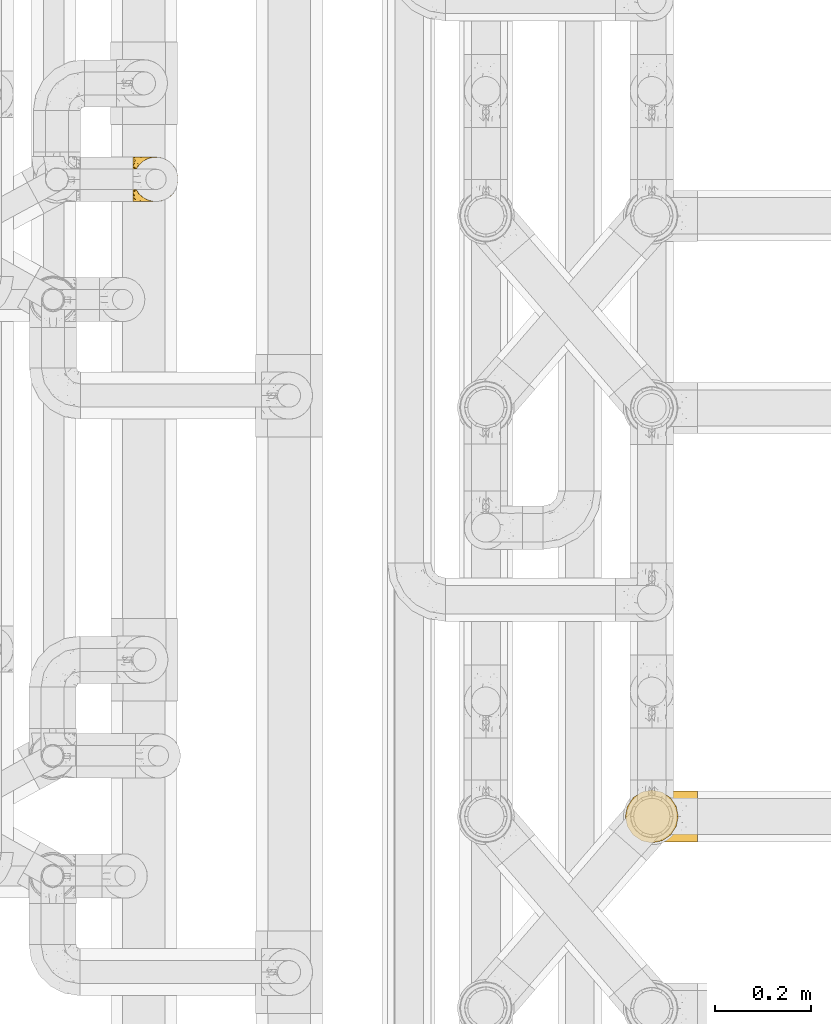
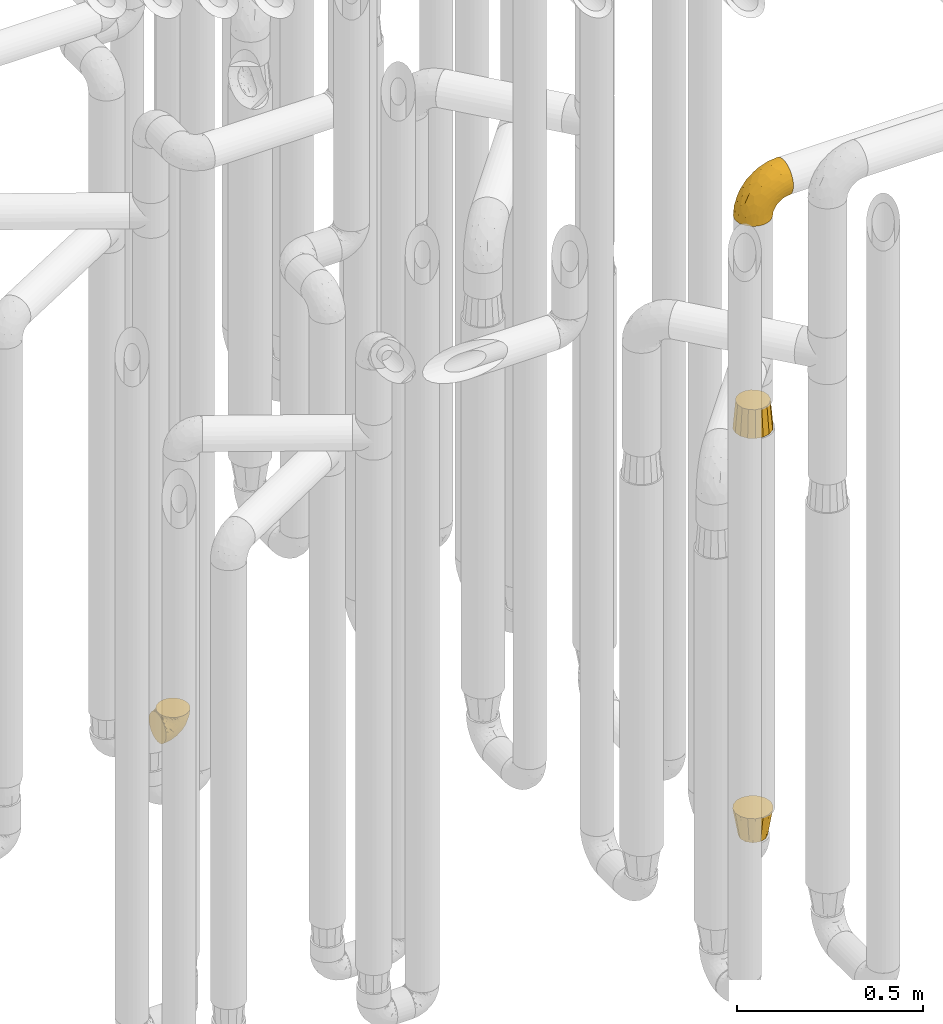
# One storey, part 208 of 827: 4 coverings.
"""IFC2X3 building model written with IfcOpenShell, lengths in millimetres."""

import ifcopenshell
import ifcopenshell.guid

model = None  # the IFC model being written
_history = None  # IfcOwnerHistory: only IFC2X3 demands one
_inside = {}  # id of a spatial element -> (the spatial element, [elements in it])
_under = {}  # id of a project, library or spatial element -> (it, [spatial elements below it])
_declared = {}  # id of a project -> (the project, [libraries it declares])
_typed = {}  # id of a type object -> (the type object, [elements of that type])
_made_of = {}  # id of a material, layer set ... -> (it, [elements and type objects made of it])


def new_model(schema):
    """Start an empty IFC model of exactly this schema.

    Asked for "IFC4X3", IfcOpenShell would pick the latest addendum, in which some entities
    have other attributes; the version numbers below select the first issue.
    IFC2X3 requires an IfcOwnerHistory on every rooted entity: one is made here for all.
    """
    global model, _history
    if schema == "IFC4X3":
        model = ifcopenshell.file(schema_version=(4, 3, 0, 0))
    else:
        model = ifcopenshell.file(schema=schema)
    _inside.clear()
    _under.clear()
    _declared.clear()
    _typed.clear()
    _made_of.clear()
    _history = None
    if model.schema == "IFC2X3":
        org = make("IfcOrganization", Name="unknown")
        user = make(
            "IfcPersonAndOrganization",
            ThePerson=make("IfcPerson", FamilyName="unknown"),
            TheOrganization=org,
        )
        app = make(
            "IfcApplication",
            ApplicationDeveloper=org,
            Version="unknown",
            ApplicationFullName="unknown",
            ApplicationIdentifier="unknown",
        )
        _history = make(
            "IfcOwnerHistory",
            OwningUser=user,
            OwningApplication=app,
            ChangeAction="ADDED",
            CreationDate=0,
        )
    return model


def make(cls, **values):
    """One entity of the class cls with the attributes given. An attribute that is None is left unset."""
    return model.create_entity(
        cls, **{name: value for name, value in values.items() if value is not None}
    )


def entity(cls, *values):
    """Any entity or typed value of the class cls, its attributes in the order of the schema. None: left unset."""
    e = model.create_entity(cls)
    for i, value in enumerate(values):
        if value is not None:
            e[i] = value
    return e


def rooted(cls, **values):
    """An entity with a GlobalId (a new one), such as an element, a storey or a relation."""
    return make(cls, GlobalId=ifcopenshell.guid.new(), OwnerHistory=_history, **values)


def si_unit(unit_type, name, prefix=None):
    """IfcSIUnit, for example si_unit("LENGTHUNIT", "METRE", prefix="MILLI")."""
    return make("IfcSIUnit", UnitType=unit_type, Prefix=prefix, Name=name)


def converted_unit(unit_type, name, factor, base, dimensions=None, offset=None):
    """IfcConversionBasedUnit, such as the inch: factor (a typed value) times the base unit."""
    return make(
        "IfcConversionBasedUnit"
        if offset is None
        else "IfcConversionBasedUnitWithOffset",
        ConversionOffset=offset,
        Dimensions=None
        if dimensions is None
        else entity("IfcDimensionalExponents", *dimensions),
        UnitType=unit_type,
        Name=name,
        ConversionFactor=make(
            "IfcMeasureWithUnit", ValueComponent=factor, UnitComponent=base
        ),
    )


def derived_unit(unit_type, elements):
    """IfcDerivedUnit: a product of units, each with its exponent."""
    return make(
        "IfcDerivedUnit",
        Elements=[
            make("IfcDerivedUnitElement", Unit=unit, Exponent=power)
            for unit, power in elements
        ],
        UnitType=unit_type,
    )


def assignment(units):
    """IfcUnitAssignment: the units of a project."""
    return None if units is None else make("IfcUnitAssignment", Units=units)


def point(xyz):
    """IfcCartesianPoint."""
    return None if xyz is None else make("IfcCartesianPoint", Coordinates=xyz)


def direction(xyz):
    """IfcDirection."""
    return None if xyz is None else make("IfcDirection", DirectionRatios=xyz)


def frame(location, z_axis=None, x_axis=None):
    """IfcAxis2Placement3D, a coordinate frame: its origin and axes. An axis left out is left unset."""
    return make(
        "IfcAxis2Placement3D",
        Location=point(location),
        Axis=direction(z_axis),
        RefDirection=direction(x_axis),
    )


def origin():
    """The frame at (0, 0, 0) with its axes left unset."""
    return frame((0.0, 0.0, 0.0))


def place(relative_to, where):
    """IfcLocalPlacement: puts the frame where relative to a parent placement (None: the world)."""
    return make(
        "IfcLocalPlacement", PlacementRelTo=relative_to, RelativePlacement=where
    )


def context(
    kind, dimensions, precision=None, world=None, true_north=None, identifier=None
):
    """IfcGeometricRepresentationContext, for example the 3D "Model" context."""
    return make(
        "IfcGeometricRepresentationContext",
        ContextIdentifier=identifier,
        ContextType=kind,
        CoordinateSpaceDimension=dimensions,
        Precision=precision,
        WorldCoordinateSystem=world,
        TrueNorth=true_north,
    )


def subcontext(parent, identifier, kind, view, scale=None):
    """IfcGeometricRepresentationSubContext, for example "Body" below "Model"."""
    return make(
        "IfcGeometricRepresentationSubContext",
        ContextIdentifier=identifier,
        ContextType=kind,
        ParentContext=parent,
        TargetScale=scale,
        TargetView=view,
    )


def project(units=None, contexts=None):
    """IfcProject with its units and contexts."""
    return rooted(
        "IfcProject",
        Name="project",
        RepresentationContexts=contexts,
        UnitsInContext=assignment(units),
    )


def spatial(cls, under=None, at=None, **own):
    """A site, building, storey or space (cls), placed at a placement, below another one or the project."""
    s = rooted(cls, ObjectPlacement=at, **own)
    if under is not None:
        _under.setdefault(under.id(), (under, []))[1].append(s)
    return s


def faces_of(points, faces, orient=None, outer=None):
    """IfcFace entities. A face is a list of loops; a loop is a list of indices into points, from 0.

    orient and outer hold one flag for each loop. By default every Orientation is true, the
    first loop of a face is its IfcFaceOuterBound and the others are IfcFaceBound.
    """
    made = []
    for i, loops in enumerate(faces):
        bounds = []
        for j, loop in enumerate(loops):
            is_outer = j == 0 if outer is None else outer[i][j]
            bounds.append(
                make(
                    "IfcFaceOuterBound" if is_outer else "IfcFaceBound",
                    Bound=make("IfcPolyLoop", Polygon=[points[k] for k in loop]),
                    Orientation=True if orient is None else orient[i][j],
                )
            )
        made.append(make("IfcFace", Bounds=bounds))
    return made


def faceted_brep(points, faces, orient=None, outer=None, voids=None):
    """IfcFacetedBrep: a solid bounded by flat faces; with voids (closed shells), ...WithVoids."""
    shared = [point(p) for p in points]
    hull = make("IfcClosedShell", CfsFaces=faces_of(shared, faces, orient, outer))
    if voids is None:
        return make("IfcFacetedBrep", Outer=hull)
    return make(
        "IfcFacetedBrepWithVoids",
        Outer=hull,
        Voids=[
            make(cls, CfsFaces=faces_of(shared, fs, o, b)) for cls, fs, o, b in voids
        ],
    )


def shape(context_of_items, identifier, shape_type, items):
    """IfcShapeRepresentation: the items that make up one representation, for example the "Body"."""
    return make(
        "IfcShapeRepresentation",
        ContextOfItems=context_of_items,
        RepresentationIdentifier=identifier,
        RepresentationType=shape_type,
        Items=items,
    )


def made_of(thing, what):
    """Note that an element or type object is made of a material, layer set ...; save() writes the relation."""
    if what is not None:
        _made_of.setdefault(what.id(), (what, []))[1].append(thing)
    return thing


def element(
    cls,
    number,
    at=None,
    inside=None,
    cuts=None,
    type_object=None,
    material=None,
    context=None,
    identifier="Body",
    shape_type=None,
    held_by="IfcProductDefinitionShape",
    body=None,
    shapes=None,
    **own,
):
    """One element of the class cls, such as IfcWall. Its Tag is "e" and its number.

    at: its placement. inside: the storey or other place that contains it. cuts: it is an
    opening in that element (IfcRelVoidsElement). A single representation is given by context,
    identifier, shape_type and body (its items); several are given by shapes. held_by: the class
    of the entity that holds the representations. save() writes the other relations.
    """
    e = rooted(cls, Tag="e%d" % number, ObjectPlacement=at, **own)
    if body is not None:
        shapes = [shape(context, identifier, shape_type, body)]
    if shapes is not None:
        e.Representation = make(held_by, Representations=shapes)
    if inside is not None:
        _inside.setdefault(inside.id(), (inside, []))[1].append(e)
    if cuts is not None:
        rooted(
            "IfcRelVoidsElement", RelatingBuildingElement=cuts, RelatedOpeningElement=e
        )
    if type_object is not None:
        _typed.setdefault(type_object.id(), (type_object, []))[1].append(e)
    return made_of(e, material)


def aggregate(whole, parts):
    """IfcRelAggregates: a whole, such as a stair, and the parts it consists of."""
    return rooted("IfcRelAggregates", RelatingObject=whole, RelatedObjects=parts)


def save(model, path):
    """Write the relations noted so far, then the file.

    IfcRelAggregates (storeys below a building ...), IfcRelContainedInSpatialStructure (elements
    in a storey), IfcRelDefinesByType, IfcRelAssociatesMaterial and IfcRelDeclares: one each for
    every whole, place, type object, material and project.
    """
    for whole, parts in _under.values():
        aggregate(whole, parts)
    for where, things in _inside.values():
        rooted(
            "IfcRelContainedInSpatialStructure",
            RelatedElements=things,
            RelatingStructure=where,
        )
    for kind, things in _typed.values():
        rooted("IfcRelDefinesByType", RelatedObjects=things, RelatingType=kind)
    for what, things in _made_of.values():
        rooted("IfcRelAssociatesMaterial", RelatedObjects=things, RelatingMaterial=what)
    for by, libraries in _declared.values():
        rooted("IfcRelDeclares", RelatingContext=by, RelatedDefinitions=libraries)
    model.write(path)


model = new_model("IFC2X3")

# Units and contexts
model_context = context("Model", 3, precision=0.01, world=origin(), true_north=direction((6.12303176911189e-17, 1.0)))
body_context = subcontext(model_context, "Body", "Model", "MODEL_VIEW")
ifc_project = project(units=[si_unit("LENGTHUNIT", "METRE", prefix="MILLI"), si_unit("AREAUNIT", "SQUARE_METRE"), si_unit("VOLUMEUNIT", "CUBIC_METRE"), converted_unit("PLANEANGLEUNIT", "DEGREE", entity("IfcRatioMeasure", 0.0174532925199433), si_unit("PLANEANGLEUNIT", "RADIAN"), dimensions=[0, 0, 0, 0, 0, 0, 0]), si_unit("MASSUNIT", "GRAM", prefix="KILO"), derived_unit("MASSDENSITYUNIT", [(si_unit("MASSUNIT", "GRAM", prefix="KILO"), 1), (si_unit("LENGTHUNIT", "METRE"), -3)]), derived_unit("MOMENTOFINERTIAUNIT", [(si_unit("LENGTHUNIT", "METRE"), 4)]), si_unit("TIMEUNIT", "SECOND"), si_unit("FREQUENCYUNIT", "HERTZ"), si_unit("THERMODYNAMICTEMPERATUREUNIT", "DEGREE_CELSIUS"), derived_unit("THERMALTRANSMITTANCEUNIT", [(si_unit("MASSUNIT", "GRAM", prefix="KILO"), 1), (si_unit("THERMODYNAMICTEMPERATUREUNIT", "KELVIN"), -1), (si_unit("TIMEUNIT", "SECOND"), -3)]), derived_unit("VOLUMETRICFLOWRATEUNIT", [(si_unit("LENGTHUNIT", "METRE"), 3), (si_unit("TIMEUNIT", "SECOND"), -1)]), derived_unit("MASSFLOWRATEUNIT", [(si_unit("MASSUNIT", "GRAM", prefix="KILO"), 1), (si_unit("TIMEUNIT", "SECOND"), -1)]), derived_unit("ROTATIONALFREQUENCYUNIT", [(si_unit("TIMEUNIT", "SECOND"), -1)]), si_unit("ELECTRICCURRENTUNIT", "AMPERE"), si_unit("ELECTRICVOLTAGEUNIT", "VOLT"), si_unit("POWERUNIT", "WATT"), si_unit("FORCEUNIT", "NEWTON", prefix="KILO"), si_unit("ILLUMINANCEUNIT", "LUX"), si_unit("LUMINOUSFLUXUNIT", "LUMEN"), si_unit("LUMINOUSINTENSITYUNIT", "CANDELA"), derived_unit("USERDEFINED", [(si_unit("MASSUNIT", "GRAM", prefix="KILO"), -1), (si_unit("LENGTHUNIT", "METRE"), -2), (si_unit("TIMEUNIT", "SECOND"), 3), (si_unit("LUMINOUSFLUXUNIT", "LUMEN"), 1)]), derived_unit("LINEARVELOCITYUNIT", [(si_unit("LENGTHUNIT", "METRE"), 1), (si_unit("TIMEUNIT", "SECOND"), -1)]), si_unit("PRESSUREUNIT", "PASCAL"), derived_unit("USERDEFINED", [(si_unit("LENGTHUNIT", "METRE"), -2), (si_unit("MASSUNIT", "GRAM", prefix="KILO"), 1), (si_unit("TIMEUNIT", "SECOND"), -2)]), derived_unit("LINEARFORCEUNIT", [(si_unit("MASSUNIT", "GRAM", prefix="KILO"), 1), (si_unit("LENGTHUNIT", "METRE"), 1), (si_unit("TIMEUNIT", "SECOND"), -2), (si_unit("LENGTHUNIT", "METRE"), -1)]), derived_unit("PLANARFORCEUNIT", [(si_unit("MASSUNIT", "GRAM", prefix="KILO"), 1), (si_unit("LENGTHUNIT", "METRE"), 1), (si_unit("TIMEUNIT", "SECOND"), -2), (si_unit("LENGTHUNIT", "METRE"), -2)])], contexts=[model_context])

# Site, building, storey
site_placement = place(None, origin())
site = spatial("IfcSite", under=ifc_project, at=site_placement, CompositionType="ELEMENT")
building_placement = place(site_placement, origin())
building = spatial("IfcBuilding", under=site, at=building_placement, CompositionType="ELEMENT")
storey_placement = place(building_placement, frame((0.0, 0.0, 28200.0)))
storey = spatial("IfcBuildingStorey", under=building, at=storey_placement, Name="08", CompositionType="ELEMENT", Elevation=28200.0)

# Coverings
covering_1_placement = place(storey_placement, frame((35893.45, 11758.41, 352.2)))
element("IfcCovering", 1, at=covering_1_placement, inside=storey, Name=":ADSK_", ObjectType=":ADSK_", PredefinedType="INSULATION", context=body_context, shape_type="Brep", body=[
    faceted_brep([(78.41, 11.68, 95.8), (85.72, 19.0, 95.8), (91.22, 27.76, 95.8), (94.64, 37.52, 95.8), (95.8, 47.8, 95.8), (94.64, 58.08, 95.8), (91.22, 67.85, 95.8), (85.71, 76.61, 95.8), (78.39, 83.92, 95.8), (69.63, 89.42, 95.8), (59.87, 92.84, 95.8), (49.6, 94.0, 95.8), (45.45, 93.53, 95.8), (42.38, 93.18, 95.8), (39.31, 92.84, 95.8), (34.43, 91.13, 95.8), (29.54, 89.42, 95.8), (25.16, 86.66, 95.8), (20.78, 83.91, 95.8), (17.13, 80.25, 95.8), (13.47, 76.59, 95.8), (7.97, 67.83, 95.8), (6.26, 62.95, 95.8), (4.55, 58.07, 95.8), (3.4, 47.8, 95.8), (4.55, 37.51, 95.8), (6.26, 32.63, 95.8), (7.97, 27.74, 95.8), (13.48, 18.98, 95.8), (17.14, 15.33, 95.8), (20.8, 11.67, 95.8), (25.18, 8.92, 95.8), (29.56, 6.17, 95.8), (34.44, 4.46, 95.8), (39.32, 2.75, 95.8), (42.39, 2.41, 95.8), (45.45, 2.06, 95.8), (49.6, 1.6, 95.8), (59.88, 2.75, 95.8), (69.65, 6.17, 95.8), (1.6, 47.8, 94.0), (1.6, 59.75, 92.42), (1.6, 70.9, 87.81), (1.6, 75.68, 84.13), (1.6, 80.46, 80.46), (1.6, 84.13, 75.68), (1.6, 87.81, 70.9), (1.6, 90.11, 65.32), (1.6, 92.42, 59.75), (1.6, 92.9, 56.14), (1.6, 93.17, 54.06), (1.6, 93.45, 51.97), (1.6, 94.0, 47.8), (1.6, 92.42, 35.84), (1.6, 87.81, 24.7), (1.6, 80.46, 15.13), (1.6, 70.9, 7.78), (1.6, 59.75, 3.17), (1.6, 47.8, 1.6), (1.6, 35.84, 3.17), (1.6, 24.7, 7.78), (1.6, 15.13, 15.13), (1.6, 7.78, 24.7), (1.6, 3.17, 35.84), (1.6, 1.6, 47.8), (1.6, 2.14, 51.97), (1.6, 2.69, 56.14), (1.6, 3.17, 59.75), (1.6, 5.48, 65.32), (1.6, 7.78, 70.9), (1.6, 11.46, 75.68), (1.6, 15.13, 80.46), (1.6, 19.91, 84.13), (1.6, 24.7, 87.81), (1.6, 35.84, 92.42), (36.81, 23.61, 15.84), (23.28, 31.99, 6.99), (45.8, 35.87, 14.39), (30.7, 47.8, 6.21), (21.2, 40.43, 4.26), (12.96, 47.8, 3.39), (66.19, 31.83, 31.2), (54.51, 23.37, 26.47), (17.98, 21.41, 11.44), (36.69, 3.07, 47.66), (35.54, 1.6, 61.85), (31.64, 1.6, 59.25), (27.75, 1.6, 56.65), (23.86, 1.6, 54.05), (19.96, 1.6, 51.45), (22.8, 13.45, 19.8), (42.67, 15.25, 26.22), (33.21, 8.07, 31.58), (59.45, 16.0, 38.36), (71.5, 17.34, 51.54), (62.66, 10.58, 51.6), (54.5, 5.34, 55.97), (47.57, 2.39, 62.88), (48.81, 8.36, 41.35), (74.98, 10.04, 82.24), (18.7, 2.59, 40.88), (15.75, 6.28, 29.0), (91.17, 34.28, 74.06), (85.28, 38.73, 54.53), (82.58, 27.25, 57.98), (75.78, 29.88, 43.81), (74.98, 38.6, 38.22), (67.27, 23.44, 38.33), (87.38, 25.25, 74.76), (82.04, 17.23, 76.85), (94.0, 47.8, 84.43), (77.8, 47.8, 40.43), (67.38, 47.8, 30.01), (56.2, 2.53, 78.67), (48.85, 1.6, 92.06), (48.11, 1.6, 88.32), (47.57, 1.6, 85.6), (47.03, 1.6, 82.88), (46.48, 1.6, 80.15), (45.94, 1.6, 77.43), (65.78, 5.71, 76.36), (17.24, 1.6, 50.91), (14.51, 1.6, 50.37), (11.79, 1.6, 49.82), (9.07, 1.6, 49.28), (7.2, 1.6, 48.91), (5.33, 1.6, 48.54), (91.18, 47.8, 66.69), (43.34, 1.6, 73.53), (40.74, 1.6, 69.64), (38.14, 1.6, 65.75), (72.73, 11.89, 66.13), (56.96, 47.8, 19.59), (62.23, 39.69, 24.64), (84.49, 47.8, 53.56), (43.83, 47.8, 12.9), (12.05, 13.84, 82.81), (18.95, 9.16, 81.22), (13.02, 15.79, 86.57), (8.34, 25.75, 92.75), (14.63, 16.09, 89.68), (11.09, 7.51, 72.26), (13.66, 3.99, 64.73), (20.08, 2.66, 62.45), (9.61, 3.16, 60.63), (9.48, 2.35, 56.91), (16.1, 2.23, 58.14), (3.42, 38.35, 93.7), (26.63, 6.18, 83.4), (33.72, 2.7, 75.54), (34.77, 2.93, 79.46), (6.75, 16.01, 82.28), (13.31, 9.08, 76.25), (21.11, 9.3, 84.69), (19.94, 11.68, 90.18), (8.67, 4.65, 65.12), (26.11, 3.65, 71.71), (29.3, 3.61, 75.21), (6.32, 12.8, 78.6), (39.92, 2.43, 87.27), (27.05, 6.83, 87.92), (6.04, 21.65, 86.94), (34.4, 3.7, 86.1), (2.87, 47.8, 94.52), (20.92, 3.37, 66.23), (27.43, 7.03, 91.08), (7.54, 7.87, 71.77), (18.45, 7.26, 76.21), (23.88, 3.41, 68.59), (7.77, 23.81, 89.94), (13.3, 86.5, 76.25), (11.09, 88.08, 72.26), (6.33, 82.79, 78.6), (9.07, 94.0, 49.28), (5.33, 94.0, 48.54), (14.51, 94.0, 50.37), (11.79, 94.0, 49.82), (3.42, 57.24, 93.7), (7.76, 71.76, 89.95), (47.03, 94.0, 82.88), (47.57, 94.0, 85.6), (48.85, 94.0, 92.06), (48.11, 94.0, 88.32), (14.62, 79.49, 89.68), (27.03, 88.75, 87.92), (20.08, 92.93, 62.45), (20.92, 92.22, 66.24), (27.75, 94.0, 56.65), (31.64, 94.0, 59.25), (9.61, 92.43, 60.63), (9.48, 93.24, 56.91), (8.33, 69.82, 92.76), (6.74, 79.57, 82.28), (12.04, 81.74, 82.81), (23.86, 94.0, 54.05), (19.96, 94.0, 51.45), (16.1, 93.36, 58.14), (19.93, 83.9, 90.18), (21.1, 86.28, 84.7), (39.92, 93.16, 87.25), (33.68, 92.88, 75.58), (29.28, 91.98, 75.2), (26.62, 89.41, 83.39), (26.08, 91.93, 71.7), (18.93, 86.42, 81.22), (27.87, 88.82, 90.73), (34.75, 92.66, 79.47), (6.04, 73.93, 86.94), (38.14, 94.0, 65.75), (12.79, 79.5, 86.75), (34.41, 91.89, 86.08), (45.94, 94.0, 77.43), (43.34, 94.0, 73.53), (40.74, 94.0, 69.64), (13.66, 91.6, 64.73), (17.24, 94.0, 50.91), (8.67, 90.94, 65.12), (35.54, 94.0, 61.85), (23.83, 92.16, 68.62), (18.43, 88.32, 76.22), (6.03, 86.13, 74.03), (46.48, 94.0, 80.15), (34.52, 93.2, 49.81), (21.2, 55.16, 4.26), (23.82, 82.02, 19.95), (41.32, 84.29, 30.61), (47.62, 76.94, 25.71), (52.66, 68.33, 22.43), (36.81, 71.98, 15.85), (49.75, 92.52, 60.69), (19.07, 92.9, 40.49), (45.8, 59.72, 14.39), (23.28, 63.6, 6.99), (21.35, 88.89, 29.56), (17.98, 74.18, 11.45), (82.57, 68.35, 57.98), (91.17, 61.33, 74.06), (85.27, 56.86, 54.52), (73.89, 68.62, 43.47), (66.19, 63.76, 31.2), (62.43, 72.19, 33.27), (63.53, 88.69, 64.26), (58.45, 92.19, 74.29), (67.16, 89.75, 80.41), (62.22, 55.9, 24.64), (81.54, 77.99, 73.62), (74.8, 85.21, 78.98), (75.83, 74.99, 53.69), (41.45, 90.23, 42.86), (76.72, 59.86, 41.67), (88.2, 70.75, 79.66), (71.6, 81.72, 58.41), (56.23, 86.53, 47.11), (59.44, 79.6, 38.37)], [[[0, 1, 2, 3, 4, 5, 6, 7, 8, 9, 10, 11, 12, 13, 14, 15, 16, 17, 18, 19, 20, 21, 22, 23, 24, 25, 26, 27, 28, 29, 30, 31, 32, 33, 34, 35, 36, 37, 38, 39]], [[40, 41, 42, 43, 44, 45, 46, 47, 48, 49, 50, 51, 52, 53, 54, 55, 56, 57, 58, 59, 60, 61, 62, 63, 64, 65, 66, 67, 68, 69, 70, 71, 72, 73, 74]], [[75, 76, 77]], [[78, 79, 80]], [[77, 81, 82]], [[76, 75, 83]], [[84, 85, 86, 87, 88, 89]], [[90, 91, 92]], [[76, 60, 59]], [[93, 94, 95]], [[90, 62, 61]], [[83, 61, 60]], [[96, 97, 84]], [[98, 93, 95]], [[0, 39, 99]], [[100, 84, 89]], [[62, 101, 63]], [[2, 102, 3]], [[92, 84, 100]], [[103, 102, 104]], [[103, 105, 106]], [[93, 107, 94]], [[1, 108, 2]], [[92, 101, 90]], [[108, 1, 109]], [[102, 110, 3]], [[93, 82, 107]], [[102, 108, 104]], [[111, 106, 112]], [[109, 0, 99]], [[113, 37, 114, 115, 116, 117, 118, 119]], [[120, 38, 113]], [[100, 89, 121, 122, 123, 124, 125, 126, 64]], [[127, 102, 103]], [[97, 119, 128, 129, 130, 85]], [[99, 120, 131]], [[132, 133, 77]], [[59, 80, 79]], [[1, 0, 109]], [[98, 84, 92]], [[94, 109, 131]], [[120, 39, 38]], [[93, 91, 82]], [[104, 94, 105]], [[97, 113, 119]], [[95, 120, 96]], [[83, 90, 61]], [[91, 93, 98]], [[64, 63, 100]], [[100, 63, 101]], [[77, 76, 79]], [[133, 106, 81]], [[84, 97, 85]], [[113, 96, 120]], [[113, 97, 96]], [[37, 113, 38]], [[110, 102, 127]], [[110, 4, 3]], [[103, 111, 134, 127]], [[90, 75, 91]], [[82, 81, 107]], [[91, 75, 82]], [[77, 82, 75]], [[76, 83, 60]], [[90, 83, 75]], [[105, 107, 81]], [[94, 131, 95]], [[105, 94, 107]], [[109, 94, 104]], [[120, 95, 131]], [[98, 95, 96]], [[84, 98, 96]], [[98, 92, 91]], [[106, 105, 81]], [[103, 104, 105]], [[112, 106, 133]], [[103, 106, 111]], [[112, 133, 132]], [[81, 77, 133]], [[77, 78, 135, 132]], [[120, 99, 39]], [[109, 99, 131]], [[59, 58, 80]], [[59, 79, 76]], [[90, 101, 62]], [[100, 101, 92]], [[2, 108, 102]], [[109, 104, 108]], [[78, 77, 79]], [[136, 137, 138]], [[27, 139, 140]], [[141, 142, 143]], [[144, 145, 121]], [[146, 89, 88]], [[147, 139, 25]], [[148, 149, 150]], [[136, 151, 152]], [[147, 40, 74]], [[24, 147, 25]], [[140, 153, 154]], [[33, 116, 34]], [[73, 72, 151]], [[114, 37, 36, 35, 34, 116, 115]], [[146, 155, 144]], [[156, 85, 130]], [[157, 149, 148]], [[151, 158, 152]], [[117, 33, 159]], [[29, 154, 160]], [[161, 74, 73]], [[162, 128, 119]], [[66, 65, 64, 126, 125, 124, 123, 122, 67]], [[163, 147, 24]], [[27, 140, 28]], [[149, 129, 150]], [[139, 27, 26, 25]], [[68, 144, 69]], [[129, 128, 150]], [[164, 87, 86]], [[130, 129, 149]], [[122, 145, 67]], [[154, 153, 148]], [[162, 119, 159]], [[165, 30, 160]], [[150, 160, 148]], [[128, 162, 150]], [[30, 165, 31]], [[145, 144, 68]], [[89, 146, 144]], [[87, 164, 143]], [[166, 155, 142]], [[88, 87, 143]], [[162, 160, 150]], [[160, 30, 29]], [[154, 29, 28]], [[140, 154, 28]], [[160, 154, 148]], [[140, 137, 153]], [[157, 148, 153]], [[156, 130, 157]], [[153, 137, 157]], [[157, 137, 156]], [[167, 137, 136]], [[168, 85, 156]], [[152, 168, 167]], [[167, 168, 156]], [[164, 152, 141]], [[71, 158, 72]], [[152, 167, 136]], [[88, 142, 146]], [[144, 155, 69]], [[146, 142, 155]], [[70, 166, 71]], [[142, 141, 166]], [[70, 69, 155]], [[141, 158, 71]], [[161, 73, 151]], [[138, 137, 140]], [[161, 136, 169]], [[136, 161, 151]], [[74, 161, 169]], [[152, 158, 141]], [[151, 72, 158]], [[168, 152, 164]], [[137, 167, 156]], [[164, 86, 168]], [[85, 168, 86]], [[116, 33, 117]], [[130, 149, 157]], [[67, 145, 68]], [[121, 89, 144]], [[145, 122, 121]], [[40, 147, 163]], [[169, 147, 74]], [[159, 33, 32]], [[162, 159, 32]], [[159, 119, 118, 117]], [[139, 147, 169]], [[139, 169, 138]], [[162, 32, 31]], [[141, 143, 164]], [[88, 143, 142]], [[71, 166, 141]], [[155, 166, 70]], [[139, 138, 140]], [[169, 136, 138]], [[160, 162, 165]], [[162, 31, 165]], [[170, 171, 172]], [[173, 174, 52, 51, 50, 49, 48, 175, 176]], [[177, 178, 41]], [[179, 15, 180]], [[12, 11, 181, 182, 180, 14, 13]], [[183, 21, 20]], [[19, 18, 184]], [[185, 186, 187]], [[186, 188, 187]], [[43, 172, 44]], [[189, 190, 47]], [[23, 22, 21, 191]], [[170, 192, 193]], [[40, 163, 177]], [[194, 195, 196]], [[24, 23, 177]], [[197, 198, 183]], [[199, 15, 179]], [[47, 46, 189]], [[200, 201, 202]], [[201, 203, 204]], [[205, 206, 184]], [[207, 41, 178]], [[16, 15, 199]], [[14, 180, 15]], [[202, 201, 198]], [[208, 201, 200]], [[163, 24, 177]], [[48, 47, 190]], [[196, 195, 189]], [[197, 184, 202]], [[204, 193, 209]], [[210, 211, 212]], [[206, 212, 213]], [[205, 17, 210]], [[184, 206, 202]], [[210, 212, 206]], [[185, 194, 214]], [[189, 215, 190]], [[216, 45, 214]], [[186, 171, 170]], [[189, 216, 196]], [[197, 20, 19]], [[194, 185, 187]], [[197, 183, 20]], [[184, 197, 19]], [[197, 202, 198]], [[206, 200, 202]], [[204, 183, 198]], [[201, 208, 203]], [[203, 208, 217]], [[204, 198, 201]], [[217, 188, 218]], [[193, 219, 170]], [[171, 186, 185]], [[170, 218, 186]], [[170, 219, 218]], [[42, 207, 192]], [[171, 220, 172]], [[216, 189, 46]], [[214, 194, 196]], [[44, 220, 45]], [[214, 196, 216]], [[216, 46, 45]], [[214, 45, 220]], [[192, 43, 42]], [[204, 203, 219]], [[207, 193, 192]], [[209, 193, 178]], [[41, 207, 42]], [[193, 207, 178]], [[43, 192, 172]], [[170, 172, 192]], [[204, 219, 193]], [[219, 203, 218]], [[217, 218, 203]], [[188, 186, 218]], [[206, 213, 200]], [[208, 200, 213]], [[199, 210, 16]], [[215, 189, 195]], [[215, 175, 190]], [[175, 48, 190]], [[199, 179, 221, 211]], [[210, 199, 211]], [[23, 191, 177]], [[40, 177, 41]], [[178, 177, 191]], [[21, 183, 191]], [[209, 191, 183]], [[205, 18, 17]], [[17, 16, 210]], [[171, 185, 214]], [[172, 220, 44]], [[214, 220, 171]], [[191, 209, 178]], [[204, 209, 183]], [[206, 205, 210]], [[18, 205, 184]], [[222, 195, 194, 187, 188, 217]], [[57, 223, 80]], [[224, 225, 226]], [[226, 227, 228]], [[229, 217, 208, 213, 212, 211]], [[230, 52, 174, 173, 176, 175, 215, 195]], [[231, 232, 228]], [[231, 78, 223]], [[223, 57, 232]], [[224, 233, 225]], [[233, 54, 53]], [[234, 232, 56]], [[56, 55, 234]], [[234, 224, 228]], [[235, 236, 237]], [[224, 55, 54]], [[238, 239, 240]], [[52, 230, 53]], [[241, 242, 243]], [[227, 244, 231]], [[11, 10, 242]], [[236, 6, 5]], [[7, 245, 8]], [[8, 246, 9]], [[238, 247, 235]], [[222, 229, 248]], [[242, 211, 221, 179, 180, 182, 181, 11]], [[233, 53, 230]], [[111, 112, 249]], [[250, 6, 236]], [[246, 251, 241]], [[6, 250, 7]], [[127, 236, 110]], [[248, 229, 252]], [[246, 8, 245]], [[235, 245, 250]], [[236, 5, 110]], [[235, 249, 238]], [[237, 236, 127]], [[243, 9, 246]], [[252, 229, 241]], [[56, 232, 57]], [[222, 230, 195]], [[225, 248, 252]], [[248, 233, 230]], [[54, 233, 224]], [[231, 228, 227]], [[244, 132, 231]], [[248, 225, 233]], [[226, 225, 253]], [[235, 250, 236]], [[245, 7, 250]], [[251, 246, 245]], [[243, 246, 241]], [[247, 245, 235]], [[252, 251, 253]], [[229, 222, 217]], [[230, 222, 248]], [[5, 4, 110]], [[237, 127, 134, 111]], [[238, 249, 239]], [[224, 234, 55]], [[232, 234, 228]], [[242, 241, 229]], [[10, 9, 243]], [[211, 242, 229]], [[10, 243, 242]], [[80, 223, 78]], [[80, 58, 57]], [[231, 223, 232]], [[227, 240, 239]], [[224, 226, 228]], [[240, 226, 253]], [[227, 239, 244]], [[226, 240, 227]], [[251, 247, 253]], [[240, 253, 247]], [[249, 235, 237]], [[237, 111, 249]], [[112, 132, 244]], [[112, 244, 249]], [[78, 231, 132, 135]], [[249, 244, 239]], [[247, 238, 240]], [[245, 247, 251]], [[251, 252, 241]], [[225, 252, 253]]]),
])
covering_2_placement = place(storey_placement, frame((36920.39, 10425.56, 2503.4)))
element("IfcCovering", 2, at=covering_2_placement, inside=storey, Name=":ADSK_", ObjectType=":ADSK_", PredefinedType="INSULATION", context=body_context, shape_type="Brep", body=[
    faceted_brep([(149.65, 66.44, 148.32), (149.65, 54.65, 149.65), (149.65, 42.84, 148.31), (149.65, 31.62, 144.39), (149.65, 21.56, 138.06), (149.65, 13.16, 129.66), (149.65, 6.84, 119.6), (149.65, 2.92, 108.39), (149.65, 1.6, 96.6), (149.65, 2.93, 84.79), (149.65, 6.85, 73.57), (149.65, 13.18, 63.51), (149.65, 21.58, 55.11), (149.65, 31.64, 48.79), (149.65, 42.85, 44.87), (149.65, 54.65, 43.55), (149.65, 66.46, 44.88), (149.65, 77.67, 48.8), (149.65, 87.73, 55.13), (149.65, 96.13, 63.53), (149.65, 102.45, 73.59), (149.65, 106.37, 84.8), (149.65, 107.7, 96.6), (149.65, 106.36, 108.41), (149.65, 102.44, 119.62), (149.65, 96.11, 129.68), (149.65, 87.71, 138.08), (149.65, 77.65, 144.4), (105.89, 40.91, 1.6), (100.59, 28.12, 1.6), (92.16, 17.13, 1.6), (81.17, 8.7, 1.6), (68.38, 3.4, 1.6), (54.65, 1.6, 1.6), (40.91, 3.4, 1.6), (28.12, 8.7, 1.6), (17.13, 17.13, 1.6), (8.7, 28.12, 1.6), (3.4, 40.91, 1.6), (1.6, 54.65, 1.6), (3.4, 68.38, 1.6), (8.7, 81.17, 1.6), (17.13, 92.16, 1.6), (28.12, 100.59, 1.6), (40.91, 105.89, 1.6), (54.65, 107.7, 1.6), (68.38, 105.89, 1.6), (81.17, 100.59, 1.6), (92.16, 92.16, 1.6), (100.59, 81.17, 1.6), (105.89, 68.38, 1.6), (107.7, 54.65, 1.6), (14.05, 85.53, 27.97), (9.45, 73.42, 37.09), (22.36, 83.77, 58.27), (4.7, 64.22, 27.13), (6.64, 54.65, 39.91), (81.47, 96.72, 109.11), (56.83, 93.36, 94.41), (64.02, 84.47, 110.94), (34.04, 71.37, 89.69), (21.43, 54.65, 75.62), (44.96, 54.65, 106.28), (49.8, 103.47, 60.12), (35.43, 100.91, 41.41), (42.1, 99.1, 63.22), (43.59, 105.43, 32.05), (57.88, 106.79, 52.13), (91.8, 89.81, 123.27), (88.01, 79.59, 129.32), (115.65, 81.29, 138.3), (18.94, 74.01, 62.95), (12.83, 64.14, 55.89), (24.96, 94.75, 37.4), (111.33, 54.65, 144.6), (113.8, 70.74, 142.66), (60.89, 68.3, 117.85), (86.24, 66.05, 134.01), (65.84, 100.73, 89.25), (124.58, 106.78, 103.34), (121.36, 103.6, 113.52), (72.79, 107.7, 57.43), (66.04, 107.7, 44.19), (59.29, 107.7, 30.95), (73.26, 106.07, 77.98), (121.69, 90.59, 132.66), (109.82, 97.43, 121.52), (40.11, 84.51, 86.93), (36.57, 93.3, 68.4), (93.81, 107.7, 78.45), (83.3, 107.7, 67.94), (136.6, 107.7, 94.53), (120.29, 107.7, 91.95), (99.11, 106.79, 93.36), (107.05, 107.7, 85.2), (91.12, 103.47, 101.45), (75.62, 54.65, 129.81), (56.97, 107.7, 16.27), (126.65, 76.99, 42.46), (116.55, 84.28, 40.4), (120.09, 91.11, 49.71), (76.06, 106.26, 39.4), (83.69, 102.6, 31.26), (71.88, 106.08, 27.7), (66.92, 106.56, 16.7), (110.43, 105.36, 70.67), (121.31, 106.74, 81.69), (81.0, 101.59, 16.68), (113.32, 54.65, 22.57), (111.09, 54.65, 14.26), (109.14, 67.71, 17.68), (95.86, 91.36, 19.58), (99.07, 94.33, 33.49), (106.92, 87.1, 33.01), (131.39, 65.84, 40.69), (136.98, 54.65, 40.15), (128.67, 54.65, 37.93), (117.07, 68.92, 31.04), (96.39, 100.82, 45.29), (106.61, 79.83, 23.55), (103.72, 77.13, 11.36), (92.14, 105.9, 59.1), (107.13, 101.53, 57.42), (98.03, 106.72, 68.96), (88.38, 97.75, 20.38), (130.66, 103.08, 72.46), (135.45, 106.39, 83.66), (123.57, 98.1, 60.66), (137.75, 95.02, 61.01), (133.2, 86.9, 51.85), (138.8, 74.42, 46.07), (120.99, 54.65, 30.25), (84.53, 105.28, 46.65), (108.72, 92.87, 43.0), (95.86, 17.93, 19.58), (130.67, 6.22, 72.44), (109.13, 41.58, 17.67), (93.81, 1.6, 78.45), (98.02, 2.57, 68.97), (110.43, 3.94, 70.65), (131.4, 43.46, 40.69), (126.66, 32.32, 42.45), (117.08, 40.38, 31.04), (108.74, 16.44, 42.99), (96.31, 8.47, 45.18), (99.11, 15.01, 33.46), (123.58, 11.21, 60.64), (107.12, 7.78, 57.37), (72.79, 1.6, 57.43), (66.04, 1.6, 44.19), (76.07, 3.04, 39.35), (56.97, 1.6, 16.27), (66.92, 2.73, 16.7), (120.29, 1.6, 91.95), (107.05, 1.6, 85.2), (121.26, 2.55, 81.68), (84.46, 3.98, 46.68), (83.69, 6.69, 31.26), (81.0, 7.7, 16.68), (71.88, 3.21, 27.7), (137.76, 14.28, 60.99), (133.21, 22.42, 51.84), (116.58, 25.02, 40.41), (120.1, 18.18, 49.72), (138.81, 34.89, 46.06), (136.6, 1.6, 94.53), (103.72, 32.17, 11.35), (106.96, 22.23, 33.02), (135.44, 2.91, 83.65), (88.38, 11.54, 20.38), (83.3, 1.6, 67.94), (92.12, 3.38, 59.12), (106.6, 29.46, 23.53), (59.29, 1.6, 30.95), (22.36, 25.52, 58.27), (14.05, 23.76, 27.97), (24.96, 14.54, 37.4), (35.43, 8.38, 41.41), (4.71, 45.07, 27.21), (9.45, 35.87, 37.09), (11.79, 45.14, 53.2), (57.88, 2.5, 52.13), (124.57, 2.51, 103.34), (121.37, 5.68, 113.5), (91.12, 5.82, 101.45), (56.83, 15.93, 94.41), (81.48, 12.54, 109.08), (64.05, 24.81, 110.95), (99.11, 2.5, 93.36), (73.26, 3.22, 77.98), (43.59, 3.86, 32.05), (19.5, 35.85, 64.63), (91.8, 19.47, 123.25), (121.7, 18.68, 132.65), (88.04, 29.68, 129.32), (123.34, 27.95, 139.96), (60.89, 40.99, 117.85), (34.04, 37.92, 89.69), (109.85, 11.85, 121.51), (42.1, 10.19, 63.23), (65.78, 8.55, 89.17), (113.81, 38.53, 142.66), (36.57, 15.99, 68.4), (40.12, 24.79, 86.94), (49.8, 5.82, 60.12), (86.08, 40.56, 133.2)], [[[0, 1, 2, 3, 4, 5, 6, 7, 8, 9, 10, 11, 12, 13, 14, 15, 16, 17, 18, 19, 20, 21, 22, 23, 24, 25, 26, 27]], [[28, 29, 30, 31, 32, 33, 34, 35, 36, 37, 38, 39, 40, 41, 42, 43, 44, 45, 46, 47, 48, 49, 50, 51]], [[52, 53, 54]], [[55, 39, 56]], [[57, 58, 59]], [[60, 61, 62]], [[63, 64, 65]], [[66, 63, 67]], [[68, 69, 70]], [[53, 71, 54]], [[41, 40, 53]], [[53, 72, 71]], [[73, 42, 52]], [[42, 41, 52]], [[74, 0, 75]], [[69, 76, 77]], [[43, 73, 64]], [[45, 44, 66]], [[57, 78, 58]], [[23, 79, 80]], [[67, 81, 82, 83]], [[67, 84, 81]], [[24, 23, 80]], [[25, 85, 26]], [[86, 85, 25]], [[42, 73, 43]], [[0, 27, 75]], [[25, 24, 86]], [[70, 26, 85]], [[0, 74, 1]], [[68, 85, 86]], [[66, 64, 63]], [[60, 59, 87]], [[54, 87, 88]], [[76, 60, 62]], [[84, 89, 90, 81]], [[79, 22, 91, 92]], [[77, 74, 75]], [[93, 92, 94, 89]], [[80, 86, 24]], [[40, 55, 53]], [[76, 59, 60]], [[93, 84, 95]], [[76, 62, 96]], [[55, 72, 53]], [[70, 27, 26]], [[75, 70, 69]], [[78, 84, 63]], [[93, 79, 92]], [[95, 86, 80]], [[77, 76, 96]], [[59, 69, 68]], [[57, 68, 86]], [[68, 57, 59]], [[59, 58, 87]], [[76, 69, 59]], [[88, 87, 58]], [[87, 54, 71]], [[86, 95, 57]], [[78, 57, 95]], [[84, 78, 95]], [[78, 63, 65]], [[58, 78, 65]], [[54, 88, 73]], [[84, 93, 89]], [[79, 95, 80]], [[79, 93, 95]], [[22, 79, 23]], [[66, 83, 97, 45]], [[84, 67, 63]], [[83, 66, 67]], [[64, 44, 43]], [[64, 66, 44]], [[65, 73, 88]], [[53, 52, 41]], [[73, 52, 54]], [[73, 65, 64]], [[65, 88, 58]], [[39, 55, 40]], [[72, 55, 56]], [[56, 61, 72]], [[60, 72, 61]], [[72, 60, 71]], [[87, 71, 60]], [[27, 70, 75]], [[68, 70, 85]], [[74, 77, 96]], [[69, 77, 75]], [[98, 99, 100]], [[46, 45, 97]], [[101, 102, 103]], [[103, 104, 83]], [[105, 94, 106]], [[107, 103, 102]], [[108, 109, 51, 110]], [[111, 112, 113]], [[114, 115, 116]], [[47, 104, 107]], [[110, 117, 108]], [[49, 48, 111]], [[102, 118, 112]], [[119, 120, 111]], [[50, 49, 120]], [[121, 122, 118]], [[105, 123, 89]], [[124, 48, 107]], [[20, 19, 125]], [[121, 81, 90]], [[117, 119, 99]], [[21, 20, 126]], [[22, 21, 91]], [[105, 125, 127]], [[110, 51, 50]], [[19, 128, 125]], [[16, 15, 115]], [[129, 98, 100]], [[126, 91, 21]], [[128, 129, 127]], [[122, 123, 105]], [[114, 117, 98]], [[17, 16, 130]], [[18, 128, 19]], [[129, 18, 17]], [[125, 106, 126]], [[115, 114, 16]], [[130, 129, 17]], [[114, 98, 130]], [[117, 116, 131, 108]], [[99, 119, 113]], [[122, 121, 123]], [[92, 126, 106]], [[105, 127, 122]], [[132, 121, 118]], [[114, 130, 16]], [[129, 130, 98]], [[50, 120, 110]], [[129, 128, 18]], [[125, 128, 127]], [[125, 126, 20]], [[91, 126, 92]], [[105, 89, 94]], [[105, 106, 125]], [[94, 92, 106]], [[100, 122, 127]], [[118, 122, 133]], [[112, 118, 133]], [[132, 118, 102]], [[132, 102, 101]], [[81, 121, 132]], [[82, 103, 83]], [[132, 101, 81]], [[104, 47, 46]], [[124, 107, 102]], [[48, 47, 107]], [[113, 112, 133]], [[112, 111, 124]], [[99, 113, 133]], [[111, 113, 119]], [[99, 133, 100]], [[117, 99, 98]], [[122, 100, 133]], [[127, 129, 100]], [[103, 82, 101]], [[81, 101, 82]], [[112, 124, 102]], [[48, 124, 111]], [[104, 103, 107]], [[46, 97, 104]], [[111, 120, 49]], [[83, 104, 97]], [[110, 120, 119]], [[117, 110, 119]], [[116, 117, 114]], [[123, 90, 89]], [[90, 123, 121]], [[30, 29, 134]], [[11, 10, 135]], [[51, 109, 108, 136]], [[137, 138, 139]], [[140, 141, 142]], [[143, 144, 145]], [[146, 139, 147]], [[148, 149, 150]], [[151, 32, 152]], [[153, 154, 155]], [[156, 150, 157]], [[158, 157, 159]], [[108, 142, 136]], [[31, 158, 152]], [[160, 161, 12]], [[162, 163, 143]], [[140, 142, 116]], [[142, 141, 162]], [[14, 164, 140]], [[14, 140, 115]], [[9, 8, 165]], [[160, 12, 11]], [[141, 164, 161]], [[13, 12, 161]], [[14, 115, 15]], [[28, 166, 29]], [[135, 139, 146]], [[141, 163, 162]], [[135, 146, 160]], [[143, 167, 162]], [[29, 166, 134]], [[116, 142, 108, 131]], [[165, 153, 168]], [[10, 9, 168]], [[168, 135, 10]], [[138, 147, 139]], [[158, 169, 157]], [[14, 13, 164]], [[116, 115, 140]], [[145, 167, 143]], [[135, 160, 11]], [[168, 153, 155]], [[138, 170, 171]], [[157, 144, 156]], [[147, 144, 143]], [[161, 164, 13]], [[140, 164, 141]], [[142, 172, 136]], [[136, 172, 166]], [[161, 160, 146]], [[165, 168, 9]], [[155, 139, 135]], [[139, 154, 137]], [[168, 155, 135]], [[139, 155, 154]], [[144, 147, 171]], [[163, 147, 143]], [[156, 144, 171]], [[157, 169, 145]], [[171, 148, 156]], [[173, 159, 149]], [[159, 157, 150]], [[152, 159, 173]], [[159, 152, 158]], [[31, 30, 158]], [[169, 30, 134]], [[157, 145, 144]], [[167, 134, 172]], [[134, 167, 145]], [[172, 142, 162]], [[162, 167, 172]], [[163, 141, 161]], [[161, 146, 163]], [[147, 163, 146]], [[148, 150, 156]], [[149, 159, 150]], [[30, 169, 158]], [[145, 169, 134]], [[151, 33, 32]], [[31, 152, 32]], [[152, 173, 151]], [[28, 51, 136]], [[134, 166, 172]], [[28, 136, 166]], [[147, 138, 171]], [[170, 138, 137]], [[170, 148, 171]], [[174, 175, 176]], [[35, 34, 177]], [[178, 179, 180]], [[181, 173, 149, 148]], [[182, 183, 184]], [[185, 186, 187]], [[188, 189, 137]], [[190, 33, 151, 173]], [[191, 179, 174]], [[34, 190, 177]], [[39, 38, 178]], [[192, 193, 194]], [[4, 3, 195]], [[175, 179, 37]], [[38, 37, 179]], [[35, 176, 36]], [[196, 62, 197]], [[181, 190, 173]], [[37, 36, 175]], [[183, 6, 198]], [[189, 148, 170, 137]], [[185, 199, 200]], [[3, 2, 201]], [[202, 185, 203]], [[8, 7, 182]], [[200, 184, 186]], [[183, 7, 6]], [[181, 189, 204]], [[200, 189, 184]], [[5, 198, 6]], [[187, 203, 185]], [[195, 3, 201]], [[205, 196, 194]], [[62, 61, 197]], [[186, 198, 192]], [[180, 179, 191]], [[2, 1, 74]], [[198, 193, 192]], [[193, 5, 4]], [[194, 193, 195]], [[2, 74, 201]], [[5, 193, 198]], [[205, 74, 96]], [[188, 137, 154, 153]], [[62, 196, 96]], [[56, 178, 180]], [[198, 184, 183]], [[184, 188, 182]], [[203, 197, 191]], [[205, 194, 201]], [[187, 192, 194]], [[192, 187, 186]], [[194, 196, 187]], [[197, 187, 196]], [[197, 203, 187]], [[202, 174, 176]], [[200, 186, 185]], [[184, 198, 186]], [[199, 185, 202]], [[189, 200, 204]], [[174, 202, 203]], [[176, 177, 199]], [[189, 181, 148]], [[190, 181, 204]], [[190, 204, 177]], [[190, 34, 33]], [[188, 153, 182]], [[189, 188, 184]], [[182, 153, 165, 8]], [[183, 182, 7]], [[199, 177, 204]], [[35, 177, 176]], [[176, 175, 36]], [[179, 175, 174]], [[200, 199, 204]], [[176, 199, 202]], [[203, 191, 174]], [[180, 197, 61]], [[197, 180, 191]], [[61, 56, 180]], [[39, 178, 56]], [[38, 179, 178]], [[194, 195, 201]], [[4, 195, 193]], [[74, 205, 201]], [[96, 196, 205]]]),
])
covering_3_placement = place(storey_placement, frame((36918.44, 10423.61, 1811.0)))
element("IfcCovering", 3, at=covering_3_placement, inside=storey, Name=":ADSK_", ObjectType=":ADSK_", PredefinedType="INSULATION", context=body_context, shape_type="Brep", body=[
    faceted_brep([(56.6, 104.1, 89.0), (47.51, 102.29, 89.0), (38.42, 100.48, 89.0), (30.71, 95.33, 89.0), (23.01, 90.18, 89.0), (17.86, 82.48, 89.0), (12.71, 74.77, 89.0), (10.9, 65.68, 89.0), (9.1, 56.6, 89.0), (10.9, 47.51, 89.0), (12.71, 38.42, 89.0), (17.86, 30.71, 89.0), (23.01, 23.01, 89.0), (30.71, 17.86, 89.0), (38.42, 12.71, 89.0), (47.51, 10.9, 89.0), (56.6, 9.1, 89.0), (65.68, 10.9, 89.0), (74.77, 12.71, 89.0), (82.48, 17.86, 89.0), (90.18, 23.01, 89.0), (95.33, 30.71, 89.0), (100.48, 38.42, 89.0), (102.29, 47.51, 89.0), (104.1, 56.6, 89.0), (102.29, 65.68, 89.0), (100.48, 74.77, 89.0), (95.33, 82.48, 89.0), (90.18, 90.18, 89.0), (82.48, 95.33, 89.0), (74.77, 100.48, 89.0), (65.68, 102.29, 89.0), (77.64, 5.78, 0.0), (69.69, 4.2, 0.0), (56.6, 1.6, 0.0), (43.51, 4.2, 0.0), (35.55, 5.78, 0.0), (26.63, 11.74, 0.0), (17.7, 17.7, 0.0), (11.74, 26.63, 0.0), (5.78, 35.55, 0.0), (4.2, 43.51, 0.0), (1.6, 56.6, 0.0), (4.2, 69.69, 0.0), (5.78, 77.64, 0.0), (11.74, 86.56, 0.0), (17.7, 95.49, 0.0), (26.63, 101.45, 0.0), (35.55, 107.41, 0.0), (43.51, 108.99, 0.0), (56.6, 111.6, 0.0), (69.69, 108.99, 0.0), (77.64, 107.41, 0.0), (86.56, 101.45, 0.0), (95.49, 95.49, 0.0), (101.45, 86.56, 0.0), (107.41, 77.64, 0.0), (108.99, 69.69, 0.0), (111.6, 56.6, 0.0), (108.99, 43.51, 0.0), (107.41, 35.55, 0.0), (101.45, 26.63, 0.0), (95.49, 17.7, 0.0), (86.56, 11.74, 0.0)], [[[0, 1, 2, 3, 4, 5, 6, 7, 8, 9, 10, 11, 12, 13, 14, 15, 16, 17, 18, 19, 20, 21, 22, 23, 24, 25, 26, 27, 28, 29, 30, 31]], [[32, 33, 34, 35, 36, 37, 38, 39, 40, 41, 42, 43, 44, 45, 46, 47, 48, 49, 50, 51, 52, 53, 54, 55, 56, 57, 58, 59, 60, 61, 62, 63]], [[6, 44, 43, 42, 8, 7]], [[5, 4, 46, 45, 44, 6]], [[1, 0, 50, 49, 48, 2]], [[4, 3, 2, 48, 47, 46]], [[14, 36, 35, 34, 16, 15]], [[13, 12, 38, 37, 36, 14]], [[9, 8, 42, 41, 40, 10]], [[12, 11, 10, 40, 39, 38]], [[22, 60, 59, 58, 24, 23]], [[21, 20, 62, 61, 60, 22]], [[17, 16, 34, 33, 32, 18]], [[20, 19, 18, 32, 63, 62]], [[30, 52, 51, 50, 0, 31]], [[29, 28, 54, 53, 52, 30]], [[25, 24, 58, 57, 56, 26]], [[28, 27, 26, 56, 55, 54]]]),
])
covering_4_placement = place(storey_placement, frame((36918.44, 10423.61, 476.0)))
element("IfcCovering", 4, at=covering_4_placement, inside=storey, Name=":ADSK_", ObjectType=":ADSK_", PredefinedType="INSULATION", context=body_context, shape_type="Brep", body=[
    faceted_brep([(17.7, 95.49, 89.0), (11.74, 86.56, 89.0), (5.78, 77.64, 89.0), (3.69, 67.12, 89.0), (1.6, 56.6, 89.0), (3.69, 46.07, 89.0), (5.78, 35.55, 89.0), (11.74, 26.63, 89.0), (17.7, 17.7, 89.0), (26.63, 11.74, 89.0), (35.55, 5.78, 89.0), (46.07, 3.69, 89.0), (56.6, 1.6, 89.0), (67.12, 3.69, 89.0), (77.64, 5.78, 89.0), (86.56, 11.74, 89.0), (95.49, 17.7, 89.0), (101.45, 26.63, 89.0), (107.41, 35.55, 89.0), (109.5, 46.07, 89.0), (111.6, 56.6, 89.0), (109.5, 67.12, 89.0), (107.41, 77.64, 89.0), (101.45, 86.56, 89.0), (95.49, 95.49, 89.0), (86.56, 101.45, 89.0), (77.64, 107.41, 89.0), (67.12, 109.5, 89.0), (56.6, 111.6, 89.0), (46.07, 109.5, 89.0), (35.55, 107.41, 89.0), (26.63, 101.45, 89.0), (91.24, 76.6, 0.0), (93.92, 66.6, 0.0), (96.6, 56.6, 0.0), (93.92, 46.6, 0.0), (91.24, 36.6, 0.0), (83.92, 29.27, 0.0), (76.6, 21.95, 0.0), (66.6, 19.27, 0.0), (56.6, 16.6, 0.0), (46.6, 19.27, 0.0), (36.6, 21.95, 0.0), (29.27, 29.27, 0.0), (21.95, 36.6, 0.0), (19.27, 46.6, 0.0), (16.6, 56.6, 0.0), (19.27, 66.6, 0.0), (21.95, 76.6, 0.0), (29.27, 83.92, 0.0), (36.6, 91.24, 0.0), (46.6, 93.92, 0.0), (56.6, 96.6, 0.0), (66.6, 93.92, 0.0), (76.6, 91.24, 0.0), (83.92, 83.92, 0.0)], [[[0, 1, 2, 3, 4, 5, 6, 7, 8, 9, 10, 11, 12, 13, 14, 15, 16, 17, 18, 19, 20, 21, 22, 23, 24, 25, 26, 27, 28, 29, 30, 31]], [[32, 33, 34, 35, 36, 37, 38, 39, 40, 41, 42, 43, 44, 45, 46, 47, 48, 49, 50, 51, 52, 53, 54, 55]], [[21, 20, 34]], [[54, 25, 55]], [[55, 23, 32]], [[34, 33, 21]], [[24, 55, 25]], [[54, 26, 25]], [[23, 55, 24]], [[52, 27, 53]], [[23, 22, 32]], [[33, 32, 22]], [[27, 52, 28]], [[26, 54, 53]], [[27, 26, 53]], [[33, 22, 21]], [[29, 28, 52]], [[48, 1, 49]], [[49, 31, 50]], [[52, 51, 29]], [[0, 49, 1]], [[48, 2, 1]], [[31, 49, 0]], [[46, 3, 47]], [[31, 30, 50]], [[51, 50, 30]], [[3, 46, 4]], [[2, 48, 47]], [[3, 2, 47]], [[51, 30, 29]], [[5, 4, 46]], [[42, 9, 43]], [[43, 7, 44]], [[46, 45, 5]], [[8, 43, 9]], [[42, 10, 9]], [[7, 43, 8]], [[40, 11, 41]], [[7, 6, 44]], [[45, 44, 6]], [[11, 40, 12]], [[10, 42, 41]], [[11, 10, 41]], [[45, 6, 5]], [[13, 12, 40]], [[36, 17, 37]], [[37, 15, 38]], [[40, 39, 13]], [[16, 37, 17]], [[36, 18, 17]], [[15, 37, 16]], [[34, 19, 35]], [[15, 14, 38]], [[39, 38, 14]], [[19, 34, 20]], [[18, 36, 35]], [[19, 18, 35]], [[39, 14, 13]]]),
])

save(model, "model.ifc")
